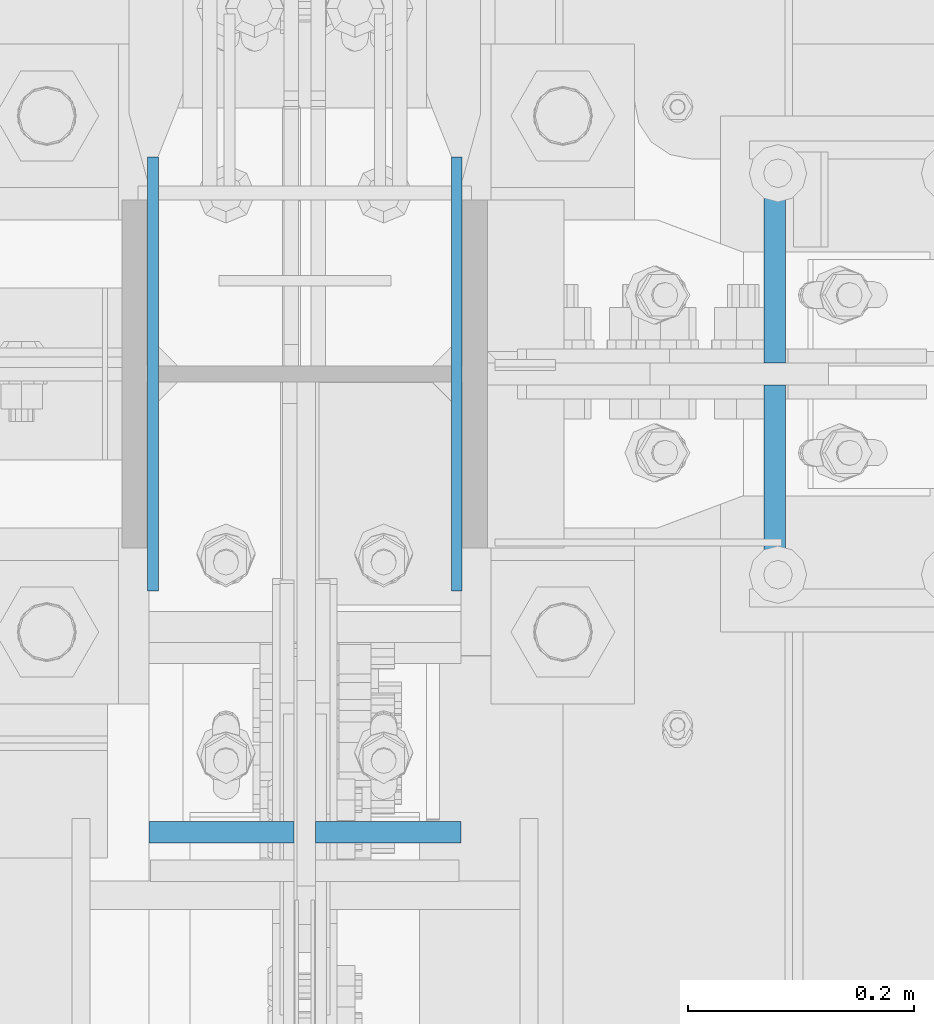
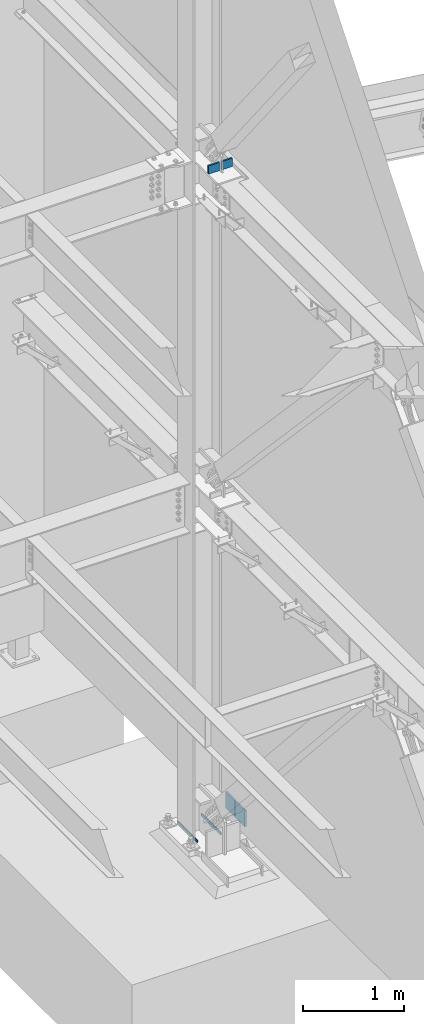
# One storey, part 555 of 1179: 6 columns, 3 elements without a shape of their own.
"""IFC2X3 building model written with IfcOpenShell, lengths in millimetres."""

from ifc_helpers import new_model, si_unit, frame, origin_with_axes, place, context, subcontext, project, spatial, faceted_brep, material, type_object, element, aggregate, save


model = new_model("IFC2X3")

# Units and contexts
model_context = context("Model", 3, precision=1e-05, world=origin_with_axes())
body_context = subcontext(model_context, "Body", "Model", "MODEL_VIEW")
ifc_project = project(units=[si_unit("LENGTHUNIT", "METRE", prefix="MILLI"), si_unit("AREAUNIT", "SQUARE_METRE"), si_unit("VOLUMEUNIT", "CUBIC_METRE"), si_unit("MASSUNIT", "GRAM", prefix="KILO"), si_unit("TIMEUNIT", "SECOND"), si_unit("PLANEANGLEUNIT", "RADIAN"), si_unit("SOLIDANGLEUNIT", "STERADIAN"), si_unit("THERMODYNAMICTEMPERATUREUNIT", "DEGREE_CELSIUS"), si_unit("LUMINOUSINTENSITYUNIT", "LUMEN")], contexts=[model_context])

# Site, building, storey
site_placement = place(None, origin_with_axes())
site = spatial("IfcSite", under=ifc_project, at=site_placement, CompositionType="ELEMENT")
building_placement = place(site_placement, origin_with_axes())
building = spatial("IfcBuilding", under=site, at=building_placement, Name="Undefined", CompositionType="ELEMENT")
storey_placement = place(building_placement, origin_with_axes())
storey = spatial("IfcBuildingStorey", under=building, at=storey_placement, Name="Undefined", CompositionType="ELEMENT", Elevation=0.0)

# Assembly, columns
assembly_1_placement = place(storey_placement, origin_with_axes())
assembly_1 = element("IfcElementAssembly", 1, at=assembly_1_placement, inside=storey, Name="COLUMN", AssemblyPlace="NOTDEFINED", PredefinedType="RIGID_FRAME")
ifc_material = material(Name="STEEL/A572-GR.50")
column_type_1 = type_object("IfcColumnType", PredefinedType="NOTDEFINED")
column_1_placement = place(assembly_1_placement, frame((24442.34025, 34391.6, -215.9), z_axis=(0.0, -1.0, 0.0), x_axis=(0.0, 0.0, 1.0)))
column_1 = element("IfcColumn", 2, at=column_1_placement, type_object=column_type_1, material=ifc_material, Name="PLATE", context=body_context, shape_type="Brep", body=[
    faceted_brep([(0.0, 4.76249999999982, -192.087500000001), (0.0, 4.76249999999982, 192.0875), (31.75, 4.76249999999982, 192.0875), (31.75, 4.76249999999982, -192.087500000001), (0.0, -4.76249999999982, 192.0875), (31.75, -4.76249999999982, 192.0875), (0.0, -4.76249999999982, -192.087500000001), (31.75, -4.76249999999982, -192.087500000001)], [[[0, 1, 2, 3]], [[1, 4, 5, 2]], [[4, 6, 7, 5]], [[6, 0, 3, 7]], [[5, 7, 3, 2]], [[6, 4, 1, 0]]]),
])
column_2_placement = place(assembly_1_placement, frame((24173.25975, 34391.6, -215.9), z_axis=(0.0, -1.0, 0.0), x_axis=(0.0, 0.0, 1.0)))
column_2 = element("IfcColumn", 3, at=column_2_placement, type_object=column_type_1, material=ifc_material, Name="PLATE", context=body_context, shape_type="Brep", body=[
    faceted_brep([(0.0, 4.76249999999982, -192.087500000001), (0.0, 4.76249999999982, 192.0875), (31.75, 4.76249999999982, 192.0875), (31.75, 4.76249999999982, -192.087500000001), (0.0, -4.76249999999982, 192.0875), (31.75, -4.76249999999982, 192.0875), (0.0, -4.76249999999982, -192.087500000001), (31.75, -4.76249999999982, -192.087500000001)], [[[0, 1, 2, 3]], [[1, 4, 5, 2]], [[4, 6, 7, 5]], [[6, 0, 3, 7]], [[5, 7, 3, 2]], [[6, 4, 1, 0]]]),
])

# Assembly, column
assembly_2_placement = place(storey_placement, origin_with_axes())
assembly_2 = element("IfcElementAssembly", 4, at=assembly_2_placement, inside=storey, Name="PLATE", AssemblyPlace="NOTDEFINED", PredefinedType="RIGID_FRAME")
column_type_2 = type_object("IfcColumnType", PredefinedType="NOTDEFINED")
column_3_placement = place(assembly_2_placement, frame((24724.004786342, 34291.5875, -215.9), z_axis=(0.0, 1.0, 0.0), x_axis=(0.0, 0.0, 1.0)))
column_3 = element("IfcColumn", 5, at=column_3_placement, type_object=column_type_2, material=ifc_material, Name="PLATE", context=body_context, shape_type="Brep", body=[
    faceted_brep([(0.0, 9.52500000000146, -90.4875000000029), (0.0, 9.52500000000146, 90.4875000000029), (198.04854092337, 9.52500000000146, 90.4875000000029), (198.04854092337, 9.52500000000146, -90.4875000000029), (0.0, -9.52500000000146, 90.4875000000029), (198.04854092337, -9.52500000000146, 90.4875000000029), (0.0, -9.52500000000146, -90.4875000000029), (198.04854092337, -9.52500000000146, -90.4875000000029)], [[[0, 1, 2, 3]], [[1, 4, 5, 2]], [[4, 6, 7, 5]], [[6, 0, 3, 7]], [[5, 7, 3, 2]], [[6, 4, 1, 0]]]),
])
aggregate(assembly_2, [column_3])

assembly_3_placement = place(storey_placement, origin_with_axes())
assembly_3 = element("IfcElementAssembly", 6, at=assembly_3_placement, inside=storey, Name="PLATE", AssemblyPlace="NOTDEFINED", PredefinedType="RIGID_FRAME")
column_4_placement = place(assembly_3_placement, frame((24724.004786342, 34491.6125, -215.9), z_axis=(0.0, -1.0, 0.0), x_axis=(0.0, 0.0, 1.0)))
column_4 = element("IfcColumn", 7, at=column_4_placement, type_object=column_type_2, material=ifc_material, Name="PLATE", context=body_context, shape_type="Brep", body=[
    faceted_brep([(0.0, 9.52500000000146, -90.4875000000029), (0.0, 9.52500000000146, 90.4875000000029), (198.04854092337, 9.52500000000146, 90.4875000000029), (198.04854092337, 9.52500000000146, -90.4875000000029), (0.0, -9.52500000000146, 90.4875000000029), (198.04854092337, -9.52500000000146, 90.4875000000029), (0.0, -9.52500000000146, -90.4875000000029), (198.04854092337, -9.52500000000146, -90.4875000000029)], [[[0, 1, 2, 3]], [[1, 4, 5, 2]], [[4, 6, 7, 5]], [[6, 0, 3, 7]], [[5, 7, 3, 2]], [[6, 4, 1, 0]]]),
])
aggregate(assembly_3, [column_4])

# Column
column_type_3 = type_object("IfcColumnType", PredefinedType="NOTDEFINED")
column_5_placement = place(assembly_1_placement, frame((24233.981, 33985.8157935486, 8013.69998747746), z_axis=(-1.0, 0.0, 0.0), x_axis=(0.0, 0.0, 1.0)))
column_5 = element("IfcColumn", 8, at=column_5_placement, type_object=column_type_3, material=ifc_material, Name="PLATE", context=body_context, shape_type="Brep", body=[
    faceted_brep([(0.0, 9.52500000000146, -64.2940000000017), (0.0, 9.52500000000146, 64.2940000000017), (100.0125, 9.52500000000146, 64.2940000000017), (100.0125, 9.52500000000146, -64.2940000000017), (0.0, -9.52500000000146, 64.2940000000017), (100.0125, -9.52500000000146, 64.2940000000017), (0.0, -9.52500000000146, -64.2940000000017), (100.0125, -9.52500000000146, -64.2940000000017)], [[[0, 1, 2, 3]], [[1, 4, 5, 2]], [[4, 6, 7, 5]], [[6, 0, 3, 7]], [[5, 7, 3, 2]], [[6, 4, 1, 0]]]),
])

column_6_placement = place(assembly_1_placement, frame((24381.619, 33985.8157935486, 8013.69998747746), z_axis=(-1.0, 0.0, 0.0), x_axis=(0.0, 0.0, 1.0)))
column_6 = element("IfcColumn", 9, at=column_6_placement, type_object=column_type_3, material=ifc_material, Name="PLATE", context=body_context, shape_type="Brep", body=[
    faceted_brep([(0.0, 9.52500000000146, -64.2940000000017), (0.0, 9.52500000000146, 64.2940000000017), (100.0125, 9.52500000000146, 64.2940000000017), (100.0125, 9.52500000000146, -64.2940000000017), (0.0, -9.52500000000146, 64.2940000000017), (100.0125, -9.52500000000146, 64.2940000000017), (0.0, -9.52500000000146, -64.2940000000017), (100.0125, -9.52500000000146, -64.2940000000017)], [[[0, 1, 2, 3]], [[1, 4, 5, 2]], [[4, 6, 7, 5]], [[6, 0, 3, 7]], [[5, 7, 3, 2]], [[6, 4, 1, 0]]]),
])

aggregate(assembly_1, [column_1, column_2, column_5, column_6])

save(model, "model.ifc")
